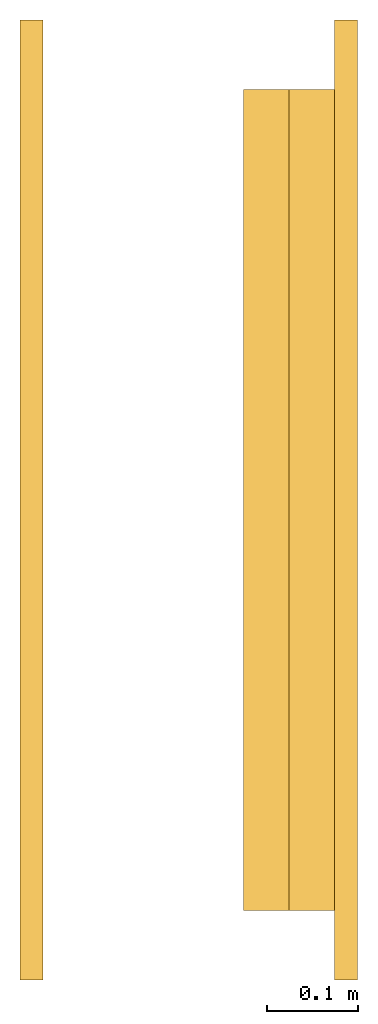
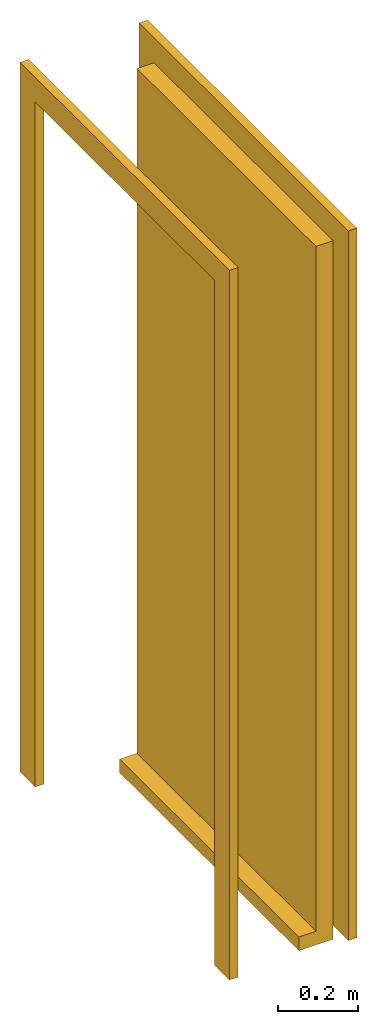
# One storey: 1 door.
"""IFC2X3 building model written with IfcOpenShell, lengths in millimetres."""

from ifc_helpers import new_model, entity, si_unit, converted_unit, derived_unit, direction, frame, frame_2d, origin, origin_2d_with_axis, place, context, subcontext, project, spatial, polyline, rectangle, outline, extrude, source, transform, mapped, material, material_list, type_object, type_shapes, element, save


model = new_model("IFC2X3")

# Units and contexts
model_context = context("Model", 3, precision=0.01, world=origin(), true_north=direction((6.12303176911189e-17, 1.0)))
body_context = subcontext(model_context, "Body", "Model", "MODEL_VIEW")
ifc_project = project(units=[si_unit("LENGTHUNIT", "METRE", prefix="MILLI"), si_unit("AREAUNIT", "SQUARE_METRE"), si_unit("VOLUMEUNIT", "CUBIC_METRE"), converted_unit("PLANEANGLEUNIT", "DEGREE", entity("IfcRatioMeasure", 0.0174532925199433), si_unit("PLANEANGLEUNIT", "RADIAN"), dimensions=[0, 0, 0, 0, 0, 0, 0]), si_unit("MASSUNIT", "GRAM", prefix="KILO"), derived_unit("MASSDENSITYUNIT", [(si_unit("MASSUNIT", "GRAM", prefix="KILO"), 1), (si_unit("LENGTHUNIT", "METRE"), -3)]), si_unit("TIMEUNIT", "SECOND"), si_unit("FREQUENCYUNIT", "HERTZ"), si_unit("THERMODYNAMICTEMPERATUREUNIT", "DEGREE_CELSIUS"), derived_unit("THERMALTRANSMITTANCEUNIT", [(si_unit("MASSUNIT", "GRAM", prefix="KILO"), 1), (si_unit("THERMODYNAMICTEMPERATUREUNIT", "KELVIN"), -1), (si_unit("TIMEUNIT", "SECOND"), -3)]), derived_unit("VOLUMETRICFLOWRATEUNIT", [(si_unit("LENGTHUNIT", "METRE"), 3), (si_unit("TIMEUNIT", "SECOND"), -1)]), si_unit("ELECTRICCURRENTUNIT", "AMPERE"), si_unit("ELECTRICVOLTAGEUNIT", "VOLT"), si_unit("POWERUNIT", "WATT"), si_unit("FORCEUNIT", "NEWTON", prefix="KILO"), si_unit("ILLUMINANCEUNIT", "LUX"), si_unit("LUMINOUSFLUXUNIT", "LUMEN"), si_unit("LUMINOUSINTENSITYUNIT", "CANDELA"), derived_unit("USERDEFINED", [(si_unit("MASSUNIT", "GRAM", prefix="KILO"), -1), (si_unit("LENGTHUNIT", "METRE"), -2), (si_unit("TIMEUNIT", "SECOND"), 3), (si_unit("LUMINOUSFLUXUNIT", "LUMEN"), 1)]), derived_unit("LINEARVELOCITYUNIT", [(si_unit("LENGTHUNIT", "METRE"), 1), (si_unit("TIMEUNIT", "SECOND"), -1)]), si_unit("PRESSUREUNIT", "PASCAL"), derived_unit("USERDEFINED", [(si_unit("LENGTHUNIT", "METRE"), -2), (si_unit("MASSUNIT", "GRAM", prefix="KILO"), 1), (si_unit("TIMEUNIT", "SECOND"), -2)])], contexts=[model_context])

# Site, building, storey
site_placement = place(None, origin())
site = spatial("IfcSite", under=ifc_project, at=site_placement, CompositionType="ELEMENT")
building_placement = place(site_placement, origin())
building = spatial("IfcBuilding", under=site, at=building_placement, CompositionType="ELEMENT")
storey_placement = place(building_placement, frame((0.0, 0.0, 16000.0)))
storey = spatial("IfcBuildingStorey", under=building, at=storey_placement, Name="04 Roof", CompositionType="ELEMENT", Elevation=16000.0)

# Door
ifc_material_1 = material(Name="Wood - Birch - Solid Stained Light Low Gloss")
ifc_material_2 = material(Name="Paint - Sienna")
ifc_material_list_1 = material_list([ifc_material_1, ifc_material_2])
ifc_material_list_2 = material_list([ifc_material_1, ifc_material_2])
door_style = type_object("IfcDoorStyle", Name="900 x 2100mm Exterior", ConstructionType="NOTDEFINED", OperationType="NOTDEFINED", ParameterTakesPrecedence=False, Sizeable=False, material=ifc_material_list_2)
shared_shape = source(origin(), body_context, "Body", "SweptSolid", [
    extrude(rectangle(XDim=50.0000000015402, YDim=900.0, at=origin_2d_with_axis()), frame((450.0, 295.0, 42.0), z_axis=(0.0, 0.0, 1.0), x_axis=(0.0, 1.0, 0.0)), (0.0, 0.0, 1.0), 2100.0),
    extrude(outline(polyline([(-526.2, -1107.15), (526.2, -1107.15), (526.2, 1069.05), (450.0, 1069.05), (450.0, -1030.95), (-450.0, -1030.95), (-450.0, 1069.05), (-526.2, 1069.05), (-526.2, -1107.15)])), frame((450.0, 320.0, 1111.05), z_axis=(0.0, 1.0, 0.0), x_axis=(1.0, 0.0, 0.0)), (0.0, 0.0, 1.0), 25.0),
    extrude(outline(polyline([(-1107.15, -526.199999999997), (1069.05, -526.199999999997), (1069.05, -450.0), (-1030.95, -450.0), (-1030.95, 450.0), (1069.05, 450.0), (1069.05, 526.200000000003), (-1107.15, 526.200000000003), (-1107.15, -526.199999999997)])), frame((450.0, -25.0, 1111.05), z_axis=(0.0, 1.0, 0.0), x_axis=(0.0, 0.0, -1.0)), (0.0, 0.0, 1.0), 25.0),
    extrude(rectangle(XDim=900.0, YDim=100.0, at=frame_2d((0.0, -2.48689957516035e-14), x_axis=(1.0, 0.0))), frame((450.0, 270.0, 0.0), z_axis=(0.0, 0.0, 1.0), x_axis=(-1.0, 0.0, 0.0)), (0.0, 0.0, 1.0), 42.0),
])
type_shapes(door_style, [shared_shape])
door_placement = place(storey_placement, frame((30943.4900708518, -72540.8241905964, 700.0), z_axis=(0.0, 0.0, 1.0), x_axis=(0.0, -1.0, 0.0)))
element("IfcDoor", 1, at=door_placement, inside=storey, type_object=door_style, material=ifc_material_list_1, Name="M_Door-Single-Panel:900 x 2100mm Exterior", ObjectType="M_Door-Single-Panel:900 x 2100mm Exterior", OverallHeight=2218.2, OverallWidth=1052.4, context=body_context, shape_type="MappedRepresentation", body=[
    mapped(shared_shape, transform((0.0, 0.0, 0.0), scale=1.0)),
])

save(model, "model.ifc")
